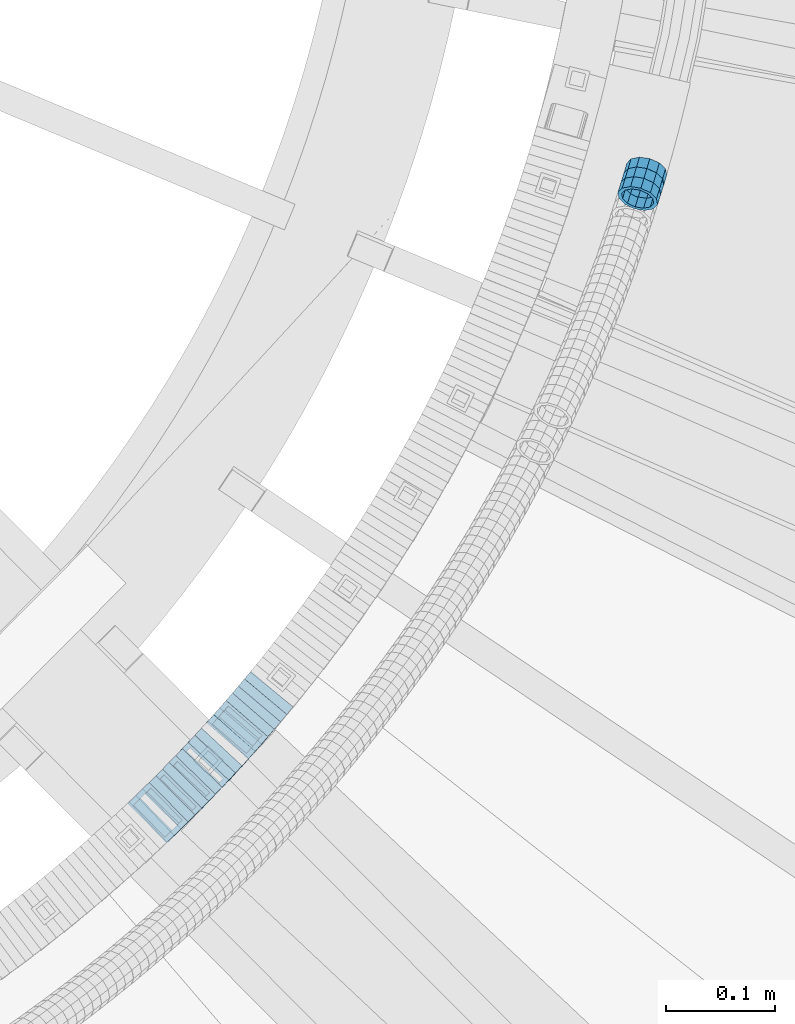
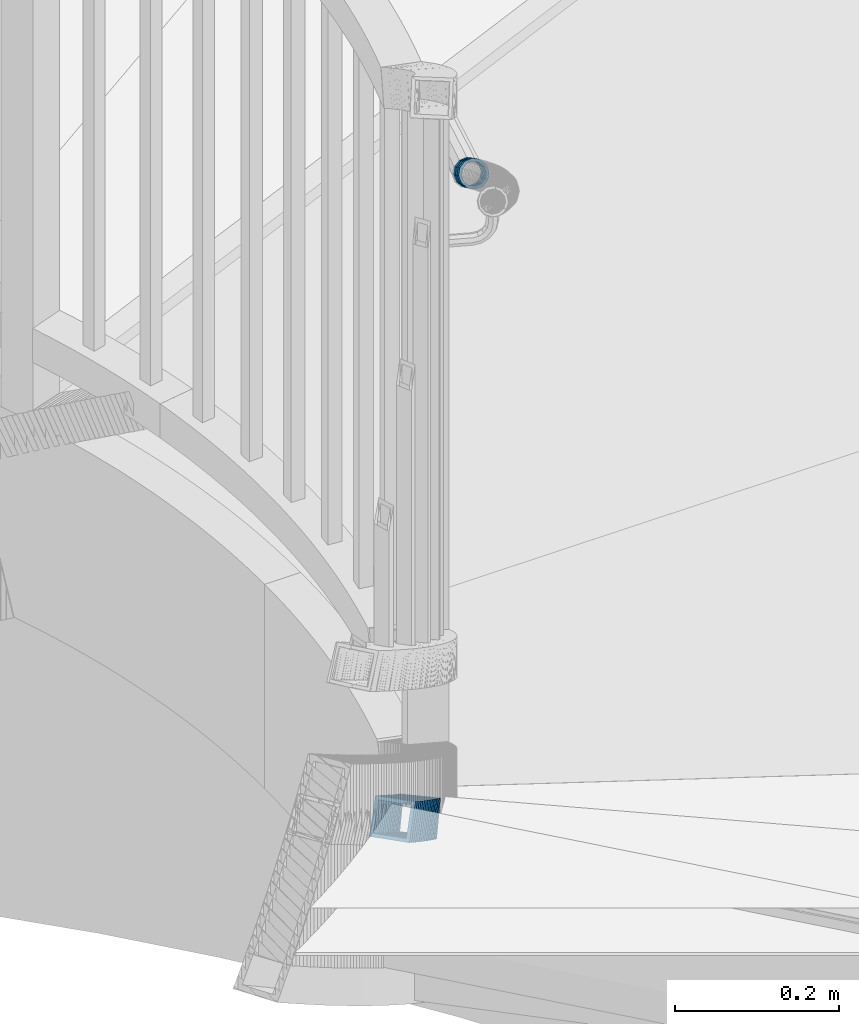
# One storey, part 791 of 975: 19 members.
"""IFC2X3 building model written with IfcOpenShell, lengths in millimetres."""

from ifc_helpers import new_model, si_unit, frame, origin_with_axes, place, context, subcontext, project, spatial, faceted_brep, material, type_object, element, save


model = new_model("IFC2X3")

# Units and contexts
model_context = context("Model", 3, precision=1e-05, world=origin_with_axes())
body_context = subcontext(model_context, "Body", "Model", "MODEL_VIEW")
ifc_project = project(units=[si_unit("LENGTHUNIT", "METRE", prefix="MILLI"), si_unit("AREAUNIT", "SQUARE_METRE"), si_unit("VOLUMEUNIT", "CUBIC_METRE"), si_unit("MASSUNIT", "GRAM", prefix="KILO"), si_unit("TIMEUNIT", "SECOND"), si_unit("PLANEANGLEUNIT", "RADIAN"), si_unit("SOLIDANGLEUNIT", "STERADIAN"), si_unit("THERMODYNAMICTEMPERATUREUNIT", "DEGREE_CELSIUS"), si_unit("LUMINOUSINTENSITYUNIT", "LUMEN")], contexts=[model_context])

# Site, building, storey
site_placement = place(None, origin_with_axes())
site = spatial("IfcSite", under=ifc_project, at=site_placement, CompositionType="ELEMENT")
building_placement = place(site_placement, origin_with_axes())
building = spatial("IfcBuilding", under=site, at=building_placement, Name="Undefined", CompositionType="ELEMENT")
storey_placement = place(building_placement, origin_with_axes())
storey = spatial("IfcBuildingStorey", under=building, at=storey_placement, Name="Undefined", CompositionType="ELEMENT", Elevation=0.0)

# Members
ifc_material = material()
member_type_1 = type_object("IfcMemberType", PredefinedType="NOTDEFINED")
member_1_placement = place(storey_placement, frame((36149.7820135626, 2972.63494042031, 3043.43100263538), z_axis=(0.955779008826956, -0.294085848496255, -2.62300090980717e-10), x_axis=(-0.251153905969039, -0.816250195900279, 0.520247376936444)))
element("IfcMember", 1, at=member_1_placement, inside=storey, type_object=member_type_1, material=ifc_material, Name="WALL", context=body_context, shape_type="Brep", body=[
    faceted_brep([(-2.1246523829177e-07, -15.367000000002, 0.0), (-1.83998054126278e-07, -13.3082123799541, 7.68350000000009), (11.154819586176, -13.3082123799522, 7.68349999999919), (11.1548195861815, -15.3669999999929, -2.91038304567337e-11), (-1.06232619145885e-07, -7.68349999999919, 13.3082123799559), (11.1548195861706, -7.68349999999737, 13.3082123799686), (-3.63797880709171e-12, 3.63797880709171e-12, 15.3670000000002), (11.1548195861687, 1.81898940354586e-12, 15.3670000000202), (1.06225343188271e-07, 7.68350000000646, 13.3082123799559), (11.1548195861687, 7.683500000001, 13.3082123799832), (1.8399441614747e-07, 13.308212379965, 7.68350000000009), (11.1548195861724, 13.3082123799559, 7.68350000001374), (2.12461600312963e-07, 15.3670000000093, 0.0), (11.1548195861778, 15.367000000002, 0.0), (1.8399441614747e-07, 13.308212379965, -7.68350000000009), (11.1548195861815, 13.3082123799613, -7.68350000002101), (1.06225343188271e-07, 7.68350000000646, -13.3082123799559), (11.1548195861869, 7.68350000000828, -13.3082123799904), (-3.63797880709171e-12, 3.63797880709171e-12, -15.3670000000002), (11.1548195861888, 9.09494701772928e-12, -15.3670000000493), (-1.06232619145885e-07, -7.68349999999919, -13.3082123799559), (11.1548195861869, -7.68349999999009, -13.308212380005), (-1.83998054126278e-07, -13.3082123799541, -7.68350000000009), (11.1548195861869, -13.3082123799468, -7.68350000003556), (-2.63386027654633e-07, -19.0500000000029, 0.0), (-2.28097633225843e-07, -16.4977839420972, -9.52499999999964), (11.1548195861869, -16.4977839420844, -9.52500000004511), (11.1548195861797, -19.0499999999938, -2.18278728425503e-11), (-1.31691194837913e-07, -9.52500000000146, -16.4977839420935), (11.1548195861906, -9.52499999998872, -16.4977839421481), (-3.63797880709171e-12, 3.63797880709171e-12, -19.0500000000002), (11.1548195861906, 9.09494701772928e-12, -19.0500000000611), (1.31687556859106e-07, 9.52500000000509, -16.4977839420935), (11.1548195861888, 9.52500000000873, -16.4977839421335), (2.28097633225843e-07, 16.4977839421044, -9.52499999999964), (11.1548195861833, 16.497783942099, -9.52500000001601), (2.63382389675826e-07, 19.0500000000138, 0.0), (11.154819586176, 19.0500000000029, 7.27595761418343e-12), (2.28097633225843e-07, 16.4977839421044, 9.52499999999964), (11.1548195861706, 16.4977839420935, 9.52500000002328), (1.31687556859106e-07, 9.52500000000509, 16.4977839420935), (11.1548195861669, 9.52499999999964, 16.497783942119), (-3.63797880709171e-12, 3.63797880709171e-12, 19.0500000000002), (11.1548195861669, -1.81898940354586e-12, 19.050000000032), (-1.31691194837913e-07, -9.52500000000146, 16.4977839420935), (11.1548195861687, -9.52499999999782, 16.4977839421117), (-2.28097633225843e-07, -16.4977839420972, 9.52499999999964), (11.154819586176, -16.4977839420881, 9.52499999999418)], [[[0, 1, 2, 3]], [[1, 4, 5, 2]], [[4, 6, 7, 5]], [[6, 8, 9, 7]], [[8, 10, 11, 9]], [[10, 12, 13, 11]], [[12, 14, 15, 13]], [[14, 16, 17, 15]], [[16, 18, 19, 17]], [[18, 20, 21, 19]], [[20, 22, 23, 21]], [[22, 0, 3, 23]], [[24, 25, 26, 27]], [[25, 28, 29, 26]], [[28, 30, 31, 29]], [[30, 32, 33, 31]], [[32, 34, 35, 33]], [[34, 36, 37, 35]], [[36, 38, 39, 37]], [[38, 40, 41, 39]], [[40, 42, 43, 41]], [[42, 44, 45, 43]], [[44, 46, 47, 45]], [[46, 24, 27, 47]], [[29, 31, 33, 35, 37, 39, 41, 43, 45, 47, 27, 26], [5, 7, 9, 11, 13, 15, 17, 19, 21, 23, 3, 2]], [[46, 44, 42, 40, 38, 36, 34, 32, 30, 28, 25, 24], [22, 20, 18, 16, 14, 12, 10, 8, 6, 4, 1, 0]]]),
])
member_2_placement = place(storey_placement, frame((36155.2620249153, 2990.6363300773, 3031.75748461078), z_axis=(0.96152394770514, -0.274721127672267, -1.43476427183486e-10), x_axis=(-0.234234233919947, -0.819819819719318, 0.522522522821093)))
element("IfcMember", 2, at=member_2_placement, inside=storey, type_object=member_type_1, material=ifc_material, Name="WALL", context=body_context, shape_type="Brep", body=[
    faceted_brep([(-2.1246523829177e-07, -15.367000000002, 0.0), (-1.83998054126278e-07, -13.3082123799541, 7.68350000000009), (11.1022520238112, -13.3082123799504, 7.68349999999919), (11.1022520238148, -15.3669999999966, -1.45519152283669e-11), (-1.06232619145885e-07, -7.68349999999919, 13.3082123799559), (11.1022520238039, -7.68349999999737, 13.3082123799759), (-3.63797880709171e-12, 3.63797880709171e-12, 15.3670000000002), (11.1022520237984, 0.0, 15.3670000000347), (1.06225343188271e-07, 7.68350000000646, 13.3082123799559), (11.102252023793, 7.68349999999737, 13.308212380005), (1.8399441614747e-07, 13.308212379965, 7.68350000000009), (11.102252023793, 13.3082123799504, 7.68350000005739), (2.12461600312963e-07, 15.3670000000093, 0.0), (11.1022520237912, 15.3669999999947, 5.82076609134674e-11), (1.8399441614747e-07, 13.308212379965, -7.68350000000009), (11.1022520237966, 13.3082123799486, -7.68349999995553), (1.06225343188271e-07, 7.68350000000646, -13.3082123799559), (11.1022520238021, 7.68349999999555, -13.3082123799322), (-3.63797880709171e-12, 3.63797880709171e-12, -15.3670000000002), (11.1022520238093, -1.81898940354586e-12, -15.3669999999984), (-1.06232619145885e-07, -7.68349999999919, -13.3082123799559), (11.102252023813, -7.68349999999919, -13.3082123799686), (-1.83998054126278e-07, -13.3082123799541, -7.68350000000009), (11.1022520238166, -13.3082123799522, -7.68350000002101), (-2.63386027654633e-07, -19.0500000000029, 0.0), (-2.28097633225843e-07, -16.4977839420972, -9.52499999999964), (11.1022520238221, -16.4977839420899, -9.52500000003056), (11.1022520238184, -19.0499999999938, -2.18278728425503e-11), (-1.31691194837913e-07, -9.52500000000146, -16.4977839420935), (11.1022520238166, -9.52499999999964, -16.4977839421117), (-3.63797880709171e-12, 3.63797880709171e-12, -19.0500000000002), (11.1022520238093, -3.63797880709171e-12, -19.0499999999956), (1.31687556859106e-07, 9.52500000000509, -16.4977839420935), (11.1022520238002, 9.52499999999418, -16.4977839420681), (2.28097633225843e-07, 16.4977839421044, -9.52499999999964), (11.1022520237948, 16.4977839420862, -9.5249999999578), (2.63382389675826e-07, 19.0500000000138, 0.0), (11.1022520237893, 19.049999999992, 5.82076609134674e-11), (2.28097633225843e-07, 16.4977839421044, 9.52499999999964), (11.1022520237893, 16.4977839420881, 9.52500000006694), (1.31687556859106e-07, 9.52500000000509, 16.4977839420935), (11.102252023793, 9.52499999999782, 16.4977839421481), (-3.63797880709171e-12, 3.63797880709171e-12, 19.0500000000002), (11.1022520237966, 0.0, 19.0500000000393), (-1.31691194837913e-07, -9.52500000000146, 16.4977839420935), (11.1022520238075, -9.524999999996, 16.4977839421117), (-2.28097633225843e-07, -16.4977839420972, 9.52499999999964), (11.1022520238148, -16.4977839420881, 9.5249999999869)], [[[0, 1, 2, 3]], [[1, 4, 5, 2]], [[4, 6, 7, 5]], [[6, 8, 9, 7]], [[8, 10, 11, 9]], [[10, 12, 13, 11]], [[12, 14, 15, 13]], [[14, 16, 17, 15]], [[16, 18, 19, 17]], [[18, 20, 21, 19]], [[20, 22, 23, 21]], [[22, 0, 3, 23]], [[24, 25, 26, 27]], [[25, 28, 29, 26]], [[28, 30, 31, 29]], [[30, 32, 33, 31]], [[32, 34, 35, 33]], [[34, 36, 37, 35]], [[36, 38, 39, 37]], [[38, 40, 41, 39]], [[40, 42, 43, 41]], [[42, 44, 45, 43]], [[44, 46, 47, 45]], [[46, 24, 27, 47]], [[29, 31, 33, 35, 37, 39, 41, 43, 45, 47, 27, 26], [5, 7, 9, 11, 13, 15, 17, 19, 21, 23, 3, 2]], [[46, 44, 42, 40, 38, 36, 34, 32, 30, 28, 25, 24], [22, 20, 18, 16, 14, 12, 10, 8, 6, 4, 1, 0]]]),
])
member_3_placement = place(storey_placement, frame((36152.4857226872, 2981.40442080969, 3037.66675568858), z_axis=(0.957826285158856, -0.287347885773997, -1.64585799211636e-10), x_axis=(-0.243351898027142, -0.81117299308944, 0.531768962058624)))
element("IfcMember", 3, at=member_3_placement, inside=storey, type_object=member_type_1, material=ifc_material, Name="WALL", context=body_context, shape_type="Brep", body=[
    faceted_brep([(-2.1246523829177e-07, -15.367000000002, 0.0), (-1.83998054126278e-07, -13.3082123799541, 7.68350000000009), (11.1022520238112, -13.3082123799504, 7.68349999999919), (11.1022520238148, -15.3669999999966, -1.45519152283669e-11), (-1.06232619145885e-07, -7.68349999999919, 13.3082123799559), (11.1022520238039, -7.68349999999737, 13.3082123799759), (-3.63797880709171e-12, 3.63797880709171e-12, 15.3670000000002), (11.1022520237984, 0.0, 15.3670000000347), (1.06225343188271e-07, 7.68350000000646, 13.3082123799559), (11.102252023793, 7.68349999999737, 13.308212380005), (1.8399441614747e-07, 13.308212379965, 7.68350000000009), (11.102252023793, 13.3082123799504, 7.68350000005739), (2.12461600312963e-07, 15.3670000000093, 0.0), (11.1022520237912, 15.3669999999947, 5.82076609134674e-11), (1.8399441614747e-07, 13.308212379965, -7.68350000000009), (11.1022520237966, 13.3082123799486, -7.68349999995553), (1.06225343188271e-07, 7.68350000000646, -13.3082123799559), (11.1022520238021, 7.68349999999555, -13.3082123799322), (-3.63797880709171e-12, 3.63797880709171e-12, -15.3670000000002), (11.1022520238093, -1.81898940354586e-12, -15.3669999999984), (-1.06232619145885e-07, -7.68349999999919, -13.3082123799559), (11.102252023813, -7.68349999999919, -13.3082123799686), (-1.83998054126278e-07, -13.3082123799541, -7.68350000000009), (11.1022520238166, -13.3082123799522, -7.68350000002101), (-2.63386027654633e-07, -19.0500000000029, 0.0), (-2.28097633225843e-07, -16.4977839420972, -9.52499999999964), (11.1022520238221, -16.4977839420899, -9.52500000003056), (11.1022520238184, -19.0499999999938, -2.18278728425503e-11), (-1.31691194837913e-07, -9.52500000000146, -16.4977839420935), (11.1022520238166, -9.52499999999964, -16.4977839421117), (-3.63797880709171e-12, 3.63797880709171e-12, -19.0500000000002), (11.1022520238093, -3.63797880709171e-12, -19.0499999999956), (1.31687556859106e-07, 9.52500000000509, -16.4977839420935), (11.1022520238002, 9.52499999999418, -16.4977839420681), (2.28097633225843e-07, 16.4977839421044, -9.52499999999964), (11.1022520237948, 16.4977839420862, -9.5249999999578), (2.63382389675826e-07, 19.0500000000138, 0.0), (11.1022520237893, 19.049999999992, 5.82076609134674e-11), (2.28097633225843e-07, 16.4977839421044, 9.52499999999964), (11.1022520237893, 16.4977839420881, 9.52500000006694), (1.31687556859106e-07, 9.52500000000509, 16.4977839420935), (11.102252023793, 9.52499999999782, 16.4977839421481), (-3.63797880709171e-12, 3.63797880709171e-12, 19.0500000000002), (11.1022520237966, 0.0, 19.0500000000393), (-1.31691194837913e-07, -9.52500000000146, 16.4977839420935), (11.1022520238075, -9.524999999996, 16.4977839421117), (-2.28097633225843e-07, -16.4977839420972, 9.52499999999964), (11.1022520238148, -16.4977839420881, 9.5249999999869)], [[[0, 1, 2, 3]], [[1, 4, 5, 2]], [[4, 6, 7, 5]], [[6, 8, 9, 7]], [[8, 10, 11, 9]], [[10, 12, 13, 11]], [[12, 14, 15, 13]], [[14, 16, 17, 15]], [[16, 18, 19, 17]], [[18, 20, 21, 19]], [[20, 22, 23, 21]], [[22, 0, 3, 23]], [[24, 25, 26, 27]], [[25, 28, 29, 26]], [[28, 30, 31, 29]], [[30, 32, 33, 31]], [[32, 34, 35, 33]], [[34, 36, 37, 35]], [[36, 38, 39, 37]], [[38, 40, 41, 39]], [[40, 42, 43, 41]], [[42, 44, 45, 43]], [[44, 46, 47, 45]], [[46, 24, 27, 47]], [[29, 31, 33, 35, 37, 39, 41, 43, 45, 47, 27, 26], [5, 7, 9, 11, 13, 15, 17, 19, 21, 23, 3, 2]], [[46, 44, 42, 40, 38, 36, 34, 32, 30, 28, 25, 24], [22, 20, 18, 16, 14, 12, 10, 8, 6, 4, 1, 0]]]),
])
member_type_2 = type_object("IfcMemberType", Name="HSS2X2X.188_TUBES", PredefinedType="NOTDEFINED")
member_4_placement = place(storey_placement, frame((35713.0261514051, 2406.30820781357, 2576.76307719514), z_axis=(0.701517264451547, -0.712652459250944, 3.59814748662756e-10), x_axis=(-0.598653957047596, -0.589299989046794, 0.542530149043077)))
element("IfcMember", 4, at=member_4_placement, inside=storey, type_object=member_type_2, material=ifc_material, Name="WALL", ObjectType="HSS2X2X.188_TUBES", context=body_context, shape_type="Brep", body=[
    faceted_brep([(0.0, 20.6374999999753, -20.6375000000298), (0.0, -20.6375000000153, -20.6375000000153), (10.6906501205649, -20.6374999999844, -20.637499999968), (10.690650120574, 20.6375000000098, -20.6374999999716), (0.0, -20.6374999999825, 20.6375000000335), (10.6906501205467, -20.6374999999844, 20.637500000008), (0.0, 20.6375000000116, 20.6375000000189), (10.6906501205558, 20.637500000008, 20.6375000000007), (0.0, 25.3999999999724, -25.4000000000342), (0.0, 25.400000000016, 25.4000000000196), (10.6906501205522, 25.4000000000087, 25.3999999999978), (10.6906501205813, 25.4000000000124, -25.3999999999651), (0.0, -25.399999999976, 25.4000000000378), (10.6906501205431, -25.3999999999833, 25.4000000000051), (0.0, -25.400000000016, -25.4000000000196), (10.6906501205704, -25.3999999999833, -25.3999999999614)], [[[0, 1, 2, 3]], [[1, 4, 5, 2]], [[4, 6, 7, 5]], [[6, 0, 3, 7]], [[8, 9, 10, 11]], [[9, 12, 13, 10]], [[12, 14, 15, 13]], [[14, 8, 11, 15]], [[13, 15, 11, 10], [5, 7, 3, 2]], [[14, 12, 9, 8], [6, 4, 1, 0]]]),
])
member_5_placement = place(storey_placement, frame((35719.1061186458, 2412.17895941383, 2571.05354306446), z_axis=(0.712740827757807, -0.701427481958838, 9.06311470316723e-11), x_axis=(-0.589487856176559, -0.598995724179502, 0.5419485121624)))
element("IfcMember", 5, at=member_5_placement, inside=storey, type_object=member_type_2, material=ifc_material, Name="WALL", ObjectType="HSS2X2X.188_TUBES", context=body_context, shape_type="Brep", body=[
    faceted_brep([(0.0, 20.6374999999753, -20.6375000000298), (0.0, -20.6375000000153, -20.6375000000153), (10.5190303735253, -20.6375000000171, -20.6375000000444), (10.5190303734962, 20.6374999999607, -20.6375000000808), (0.0, -20.6374999999825, 20.6375000000335), (10.5190303735744, -20.6374999999844, 20.6375000000407), (0.0, 20.6375000000116, 20.6375000000189), (10.5190303735435, 20.6374999999916, 20.6375000000044), (0.0, 25.3999999999724, -25.4000000000342), (0.0, 25.400000000016, 25.4000000000196), (10.5190303735435, 25.3999999999942, 25.4000000000124), (10.5190303734835, 25.3999999999523, -25.4000000000924), (0.0, -25.399999999976, 25.4000000000378), (10.5190303735853, -25.399999999976, 25.400000000056), (0.0, -25.400000000016, -25.4000000000196), (10.5190303735235, -25.4000000000196, -25.4000000000451)], [[[0, 1, 2, 3]], [[1, 4, 5, 2]], [[4, 6, 7, 5]], [[6, 0, 3, 7]], [[8, 9, 10, 11]], [[9, 12, 13, 10]], [[12, 14, 15, 13]], [[14, 8, 11, 15]], [[13, 15, 11, 10], [5, 7, 3, 2]], [[14, 12, 9, 8], [6, 4, 1, 0]]]),
])
member_6_placement = place(storey_placement, frame((35725.5152764884, 2418.69232217269, 2565.25491286781), z_axis=(0.712652459251016, -0.701517264451473, -3.59879322786582e-10), x_axis=(-0.592287356936455, -0.601688743935535, 0.535879036942579)))
element("IfcMember", 6, at=member_6_placement, inside=storey, type_object=member_type_2, material=ifc_material, Name="WALL", ObjectType="HSS2X2X.188_TUBES", context=body_context, shape_type="Brep", body=[
    faceted_brep([(0.0, 20.6374999999753, -20.6375000000298), (0.0, -20.6375000000153, -20.6375000000153), (10.6395488625676, -20.6374999999771, -20.6374999999716), (10.6395488625531, 20.6374999999916, -20.6375000000189), (0.0, -20.6374999999825, 20.6375000000335), (10.6395488625731, -20.6374999999844, 20.6375000000153), (0.0, 20.6375000000116, 20.6375000000189), (10.6395488625585, 20.6374999999825, 20.637499999968), (0.0, 25.3999999999724, -25.4000000000342), (0.0, 25.400000000016, 25.4000000000196), (10.6395488625567, 25.3999999999778, 25.3999999999614), (10.6395488625494, 25.3999999999887, -25.4000000000233), (0.0, -25.399999999976, 25.4000000000378), (10.6395488625749, -25.3999999999851, 25.400000000016), (0.0, -25.400000000016, -25.4000000000196), (10.6395488625658, -25.399999999976, -25.3999999999687)], [[[0, 1, 2, 3]], [[1, 4, 5, 2]], [[4, 6, 7, 5]], [[6, 0, 3, 7]], [[8, 9, 10, 11]], [[9, 12, 13, 10]], [[12, 14, 15, 13]], [[14, 8, 11, 15]], [[13, 15, 11, 10], [5, 7, 3, 2]], [[14, 12, 9, 8], [6, 4, 1, 0]]]),
])
member_7_placement = place(storey_placement, frame((35731.5984770764, 2424.81646858918, 2559.60322446153), z_axis=(0.718240222846302, -0.69579521576804, -3.81628524337429e-11), x_axis=(-0.586132836860171, -0.605040347855586, 0.538864059871356)))
element("IfcMember", 7, at=member_7_placement, inside=storey, type_object=member_type_2, material=ifc_material, Name="WALL", ObjectType="HSS2X2X.188_TUBES", context=body_context, shape_type="Brep", body=[
    faceted_brep([(0.0, 20.6374999999753, -20.6375000000298), (0.0, -20.6375000000153, -20.6375000000153), (10.5806427026419, -20.6374999999607, -20.6374999999316), (10.5806427026473, 20.6375000000444, -20.6374999999207), (0.0, -20.6374999999825, 20.6375000000335), (10.5806427025509, -20.6375000000207, 20.6374999999643), (0.0, 20.6375000000116, 20.6375000000189), (10.5806427025545, 20.6374999999862, 20.6374999999716), (0.0, 25.3999999999724, -25.4000000000342), (0.0, 25.400000000016, 25.4000000000196), (10.5806427025436, 25.3999999999796, 25.3999999999614), (10.5806427026582, 25.4000000000542, -25.3999999999105), (0.0, -25.399999999976, 25.4000000000378), (10.5806427025418, -25.4000000000287, 25.3999999999542), (0.0, -25.400000000016, -25.4000000000196), (10.5806427026528, -25.3999999999542, -25.3999999999178)], [[[0, 1, 2, 3]], [[1, 4, 5, 2]], [[4, 6, 7, 5]], [[6, 0, 3, 7]], [[8, 9, 10, 11]], [[9, 12, 13, 10]], [[12, 14, 15, 13]], [[14, 8, 11, 15]], [[13, 15, 11, 10], [5, 7, 3, 2]], [[14, 12, 9, 8], [6, 4, 1, 0]]]),
])
member_8_placement = place(storey_placement, frame((35737.6808177588, 2431.09501380966, 2553.91234156435), z_axis=(0.718240222846302, -0.69579521576804, -3.81628524337429e-11), x_axis=(-0.583143735824596, -0.601954824818908, 0.54552155983588)))
element("IfcMember", 8, at=member_8_placement, inside=storey, type_object=member_type_2, material=ifc_material, Name="WALL", ObjectType="HSS2X2X.188_TUBES", context=body_context, shape_type="Brep", body=[
    faceted_brep([(0.0, 20.6374999999753, -20.6375000000298), (0.0, -20.6375000000153, -20.6375000000153), (10.6348483769107, -20.637499999988, -20.6374999999825), (10.6348483768415, 20.6374999999734, -20.6375000001026), (0.0, -20.6374999999825, 20.6375000000335), (10.6348483769852, -20.6374999999589, 20.6375000001462), (0.0, 20.6375000000116, 20.6375000000189), (10.6348483769161, 20.6375000000044, 20.6375000000226), (0.0, 25.3999999999724, -25.4000000000342), (0.0, 25.400000000016, 25.4000000000196), (10.6348483769179, 25.4000000000015, 25.4000000000233), (10.6348483768288, 25.3999999999669, -25.4000000001324), (0.0, -25.399999999976, 25.4000000000378), (10.6348483769998, -25.3999999999505, 25.4000000001688), (0.0, -25.400000000016, -25.4000000000196), (10.6348483769107, -25.3999999999887, -25.3999999999833)], [[[0, 1, 2, 3]], [[1, 4, 5, 2]], [[4, 6, 7, 5]], [[6, 0, 3, 7]], [[8, 9, 10, 11]], [[9, 12, 13, 10]], [[12, 14, 15, 13]], [[14, 8, 11, 15]], [[13, 15, 11, 10], [5, 7, 3, 2]], [[14, 12, 9, 8], [6, 4, 1, 0]]]),
])
member_9_placement = place(storey_placement, frame((35743.7800747455, 2437.27769199091, 2548.10087833793), z_axis=(0.729187266868911, -0.684314204029295, 7.10215317667462e-11), x_axis=(-0.576524524206887, -0.614329411220378, 0.538719637193267)))
element("IfcMember", 9, at=member_9_placement, inside=storey, type_object=member_type_2, material=ifc_material, Name="WALL", ObjectType="HSS2X2X.188_TUBES", context=body_context, shape_type="Brep", body=[
    faceted_brep([(0.0, 20.6374999999753, -20.6375000000298), (0.0, -20.6375000000153, -20.6375000000153), (10.5806427026419, -20.6374999999607, -20.6374999999316), (10.5806427026473, 20.6375000000444, -20.6374999999207), (0.0, -20.6374999999825, 20.6375000000335), (10.5806427025509, -20.6375000000207, 20.6374999999643), (0.0, 20.6375000000116, 20.6375000000189), (10.5806427025545, 20.6374999999862, 20.6374999999716), (0.0, 25.3999999999724, -25.4000000000342), (0.0, 25.400000000016, 25.4000000000196), (10.5806427025436, 25.3999999999796, 25.3999999999614), (10.5806427026582, 25.4000000000542, -25.3999999999105), (0.0, -25.399999999976, 25.4000000000378), (10.5806427025418, -25.4000000000287, 25.3999999999542), (0.0, -25.400000000016, -25.4000000000196), (10.5806427026528, -25.3999999999542, -25.3999999999178)], [[[0, 1, 2, 3]], [[1, 4, 5, 2]], [[4, 6, 7, 5]], [[6, 0, 3, 7]], [[8, 9, 10, 11]], [[9, 12, 13, 10]], [[12, 14, 15, 13]], [[14, 8, 11, 15]], [[13, 15, 11, 10], [5, 7, 3, 2]], [[14, 12, 9, 8], [6, 4, 1, 0]]]),
])
member_10_placement = place(storey_placement, frame((35749.8783761441, 2443.72343410136, 2542.35033670451), z_axis=(0.734376708367199, -0.678742108762789, -2.68556050286861e-10), x_axis=(-0.573180696785189, -0.620162721767527, 0.535595077799207)))
element("IfcMember", 10, at=member_10_placement, inside=storey, type_object=member_type_2, material=ifc_material, Name="WALL", ObjectType="HSS2X2X.188_TUBES", context=body_context, shape_type="Brep", body=[
    faceted_brep([(0.0, 20.6374999999753, -20.6375000000298), (0.0, -20.6375000000153, -20.6375000000153), (10.6395488625676, -20.6374999999771, -20.6374999999716), (10.6395488625531, 20.6374999999916, -20.6375000000189), (0.0, -20.6374999999825, 20.6375000000335), (10.6395488625731, -20.6374999999844, 20.6375000000153), (0.0, 20.6375000000116, 20.6375000000189), (10.6395488625585, 20.6374999999825, 20.637499999968), (0.0, 25.3999999999724, -25.4000000000342), (0.0, 25.400000000016, 25.4000000000196), (10.6395488625567, 25.3999999999778, 25.3999999999614), (10.6395488625494, 25.3999999999887, -25.4000000000233), (0.0, -25.399999999976, 25.4000000000378), (10.6395488625749, -25.3999999999851, 25.400000000016), (0.0, -25.400000000016, -25.4000000000196), (10.6395488625658, -25.399999999976, -25.3999999999687)], [[[0, 1, 2, 3]], [[1, 4, 5, 2]], [[4, 6, 7, 5]], [[6, 0, 3, 7]], [[8, 9, 10, 11]], [[9, 12, 13, 10]], [[12, 14, 15, 13]], [[14, 8, 11, 15]], [[13, 15, 11, 10], [5, 7, 3, 2]], [[14, 12, 9, 8], [6, 4, 1, 0]]]),
])
member_11_placement = place(storey_placement, frame((35755.8643620431, 2450.25439157036, 2536.70994936357), z_axis=(0.729187266868911, -0.684314204029295, 7.10215317667462e-11), x_axis=(-0.573585986715, -0.611198182696374, 0.545376839729035)))
element("IfcMember", 11, at=member_11_placement, inside=storey, type_object=member_type_2, material=ifc_material, Name="WALL", ObjectType="HSS2X2X.188_TUBES", context=body_context, shape_type="Brep", body=[
    faceted_brep([(0.0, 20.6374999999753, -20.6375000000298), (0.0, -20.6375000000153, -20.6375000000153), (10.6348483769107, -20.637499999988, -20.6374999999825), (10.6348483768415, 20.6374999999734, -20.6375000001026), (0.0, -20.6374999999825, 20.6375000000335), (10.6348483769852, -20.6374999999589, 20.6375000001462), (0.0, 20.6375000000116, 20.6375000000189), (10.6348483769161, 20.6375000000044, 20.6375000000226), (0.0, 25.3999999999724, -25.4000000000342), (0.0, 25.400000000016, 25.4000000000196), (10.6348483769179, 25.4000000000015, 25.4000000000233), (10.6348483768288, 25.3999999999669, -25.4000000001324), (0.0, -25.399999999976, 25.4000000000378), (10.6348483769998, -25.3999999999505, 25.4000000001688), (0.0, -25.400000000016, -25.4000000000196), (10.6348483769107, -25.3999999999887, -25.3999999999833)], [[[0, 1, 2, 3]], [[1, 4, 5, 2]], [[4, 6, 7, 5]], [[6, 0, 3, 7]], [[8, 9, 10, 11]], [[9, 12, 13, 10]], [[12, 14, 15, 13]], [[14, 8, 11, 15]], [[13, 15, 11, 10], [5, 7, 3, 2]], [[14, 12, 9, 8], [6, 4, 1, 0]]]),
])
for number, where, z_axis, x_axis, name in (
    (12, (35761.8703566823, 2456.53938343108, 2530.89697428563), (0.739940073305354, -0.672672794095961, -8.58849489304701e-11), (-0.566820201285187, -0.623502221313754, 0.538479191270967), "WALL"),
    (13, (35767.6692874342, 2462.80194984014, 2525.19152149674), (0.750491265210869, -0.660880368026006, -7.65185177442618e-11), (-0.55702532101342, -0.632554178015136, 0.538143107012895), "WALL"),
):
    element("IfcMember", number, at=place(storey_placement, frame(where, z_axis=z_axis, x_axis=x_axis)), inside=storey, type_object=member_type_2, material=ifc_material, Name=name, ObjectType="HSS2X2X.188_TUBES", context=body_context, shape_type="Brep", body=[
        faceted_brep([(0.0, 20.6374999999753, -20.6375000000298), (0.0, -20.6375000000153, -20.6375000000153), (10.5948100501191, -20.6375000000335, -20.6375000000844), (10.5948100501555, 20.6374999999971, -20.6375000000116), (0.0, -20.6374999999825, 20.6375000000335), (10.5948100501446, -20.6375000000098, 20.6374999999571), (0.0, 20.6375000000116, 20.6375000000189), (10.5948100501828, 20.6375000000189, 20.6375000000298), (0.0, 25.3999999999724, -25.4000000000342), (0.0, 25.400000000016, 25.4000000000196), (10.5948100501919, 25.4000000000251, 25.4000000000451), (10.5948100501591, 25.3999999999978, -25.4000000000051), (0.0, -25.399999999976, 25.4000000000378), (10.5948100501482, -25.4000000000106, 25.3999999999578), (0.0, -25.400000000016, -25.4000000000196), (10.5948100501118, -25.4000000000378, -25.400000000096)], [[[0, 1, 2, 3]], [[1, 4, 5, 2]], [[4, 6, 7, 5]], [[6, 0, 3, 7]], [[8, 9, 10, 11]], [[9, 12, 13, 10]], [[12, 14, 15, 13]], [[14, 8, 11, 15]], [[13, 15, 11, 10], [5, 7, 3, 2]], [[14, 12, 9, 8], [6, 4, 1, 0]]]),
    ])
member_12_placement = place(storey_placement, frame((35773.7727183759, 2469.78974565235, 2519.44577120091), z_axis=(0.744950446796735, -0.667119803196805, 1.78856680577155e-10), x_axis=(-0.563485862174004, -0.62922587919428, 0.53531156916529)))
element("IfcMember", 14, at=member_12_placement, inside=storey, type_object=member_type_2, material=ifc_material, Name="WALL", ObjectType="HSS2X2X.188_TUBES", context=body_context, shape_type="Brep", body=[
    faceted_brep([(0.0, 20.6374999999753, -20.6375000000298), (0.0, -20.6375000000153, -20.6375000000153), (10.648004507897, -20.6374999999862, -20.637499999968), (10.6480045078188, 20.6374999999771, -20.6375000000808), (0.0, -20.6374999999825, 20.6375000000335), (10.6480045079406, -20.6374999999698, 20.6375000001062), (0.0, 20.6375000000116, 20.6375000000189), (10.6480045078679, 20.6374999999935, 20.6375000000007), (0.0, 25.3999999999724, -25.4000000000342), (0.0, 25.400000000016, 25.4000000000196), (10.6480045078661, 25.3999999999905, 25.4000000000015), (10.648004507806, 25.3999999999705, -25.4000000000997), (0.0, -25.399999999976, 25.4000000000378), (10.6480045079552, -25.3999999999633, 25.4000000001288), (0.0, -25.400000000016, -25.4000000000196), (10.6480045078988, -25.3999999999814, -25.3999999999651)], [[[0, 1, 2, 3]], [[1, 4, 5, 2]], [[4, 6, 7, 5]], [[6, 0, 3, 7]], [[8, 9, 10, 11]], [[9, 12, 13, 10]], [[12, 14, 15, 13]], [[14, 8, 11, 15]], [[13, 15, 11, 10], [5, 7, 3, 2]], [[14, 12, 9, 8], [6, 4, 1, 0]]]),
])
member_13_placement = place(storey_placement, frame((35779.2572462389, 2475.78152948542, 2513.8473468106), z_axis=(0.756061291784399, -0.654500819759078, -2.68632902589162e-11), x_axis=(-0.547633029096188, -0.632610568111114, 0.547633029096188)))
element("IfcMember", 15, at=member_13_placement, inside=storey, type_object=member_type_2, material=ifc_material, Name="WALL", ObjectType="HSS2X2X.188_TUBES", context=body_context, shape_type="Brep", body=[
    faceted_brep([(0.0, 20.6374999999753, -20.6375000000298), (0.0, -20.6375000000153, -20.6375000000153), (10.5948100501191, -20.6375000000335, -20.6375000000844), (10.5948100501555, 20.6374999999971, -20.6375000000116), (0.0, -20.6374999999825, 20.6375000000335), (10.5948100501446, -20.6375000000098, 20.6374999999571), (0.0, 20.6375000000116, 20.6375000000189), (10.5948100501828, 20.6375000000189, 20.6375000000298), (0.0, 25.3999999999724, -25.4000000000342), (0.0, 25.400000000016, 25.4000000000196), (10.5948100501919, 25.4000000000251, 25.4000000000451), (10.5948100501591, 25.3999999999978, -25.4000000000051), (0.0, -25.399999999976, 25.4000000000378), (10.5948100501482, -25.4000000000106, 25.3999999999578), (0.0, -25.400000000016, -25.4000000000196), (10.5948100501118, -25.4000000000378, -25.400000000096)], [[[0, 1, 2, 3]], [[1, 4, 5, 2]], [[4, 6, 7, 5]], [[6, 0, 3, 7]], [[8, 9, 10, 11]], [[9, 12, 13, 10]], [[12, 14, 15, 13]], [[14, 8, 11, 15]], [[13, 15, 11, 10], [5, 7, 3, 2]], [[14, 12, 9, 8], [6, 4, 1, 0]]]),
])
member_14_placement = place(storey_placement, frame((35785.3755376804, 2482.85708824703, 2507.93970037974), z_axis=(0.755322467394303, -0.655353317111756, -1.10163909994298e-10), x_axis=(-0.553703879785737, -0.638167183753146, 0.534934256793114)))
element("IfcMember", 16, at=member_14_placement, inside=storey, type_object=member_type_2, material=ifc_material, Name="WALL", ObjectType="HSS2X2X.188_TUBES", context=body_context, shape_type="Brep", body=[
    faceted_brep([(0.0, 20.6374999999753, -20.6375000000298), (0.0, -20.6375000000153, -20.6375000000153), (10.6625512894789, -20.6374999999625, -20.6374999999389), (10.6625512893879, 20.6374999999789, -20.6375000000371), (0.0, -20.6374999999825, 20.6375000000335), (10.6625512894352, -20.6374999999989, 20.6375000000153), (0.0, 20.6375000000116, 20.6375000000189), (10.6625512893443, 20.6374999999443, 20.6374999999134), (0.0, 25.3999999999724, -25.4000000000342), (0.0, 25.400000000016, 25.4000000000196), (10.6625512893297, 25.3999999999342, 25.3999999998996), (10.6625512893916, 25.399999999976, -25.4000000000415), (0.0, -25.399999999976, 25.4000000000378), (10.6625512894389, -25.399999999996, 25.400000000016), (0.0, -25.400000000016, -25.4000000000196), (10.6625512894971, -25.3999999999523, -25.3999999999214)], [[[0, 1, 2, 3]], [[1, 4, 5, 2]], [[4, 6, 7, 5]], [[6, 0, 3, 7]], [[8, 9, 10, 11]], [[9, 12, 13, 10]], [[12, 14, 15, 13]], [[14, 8, 11, 15]], [[13, 15, 11, 10], [5, 7, 3, 2]], [[14, 12, 9, 8], [6, 4, 1, 0]]]),
])
for number, where, z_axis, x_axis, name in (
    (17, (35791.0768111456, 2489.36579254663, 2502.28453276387), (0.760833952037136, -0.648946605991242, -1.96182554645929e-11), (-0.547145463784104, -0.641480888746982, 0.537711921787922), "WALL"),
    (18, (35796.5716850057, 2495.74022933671, 2496.63924652357), (0.766370513915105, -0.642398813356235, 2.14107785723172e-10), (-0.537711921787912, -0.641480888746931, 0.547145463784173), "WALL"),
):
    element("IfcMember", number, at=place(storey_placement, frame(where, z_axis=z_axis, x_axis=x_axis)), inside=storey, type_object=member_type_2, material=ifc_material, Name=name, ObjectType="HSS2X2X.188_TUBES", context=body_context, shape_type="Brep", body=[
        faceted_brep([(0.0, 20.6374999999753, -20.6375000000298), (0.0, -20.6375000000153, -20.6375000000153), (10.6004716875832, -20.6375000000153, -20.6375000000553), (10.6004716875814, 20.6374999999898, -20.6375000000444), (0.0, -20.6374999999825, 20.6375000000335), (10.6004716876068, -20.6375000000044, 20.6374999999862), (0.0, 20.6375000000116, 20.6375000000189), (10.6004716876032, 20.6374999999989, 20.6374999999971), (0.0, 25.3999999999724, -25.4000000000342), (0.0, 25.400000000016, 25.4000000000196), (10.600471687605, 25.4000000000015, 25.4000000000051), (10.6004716875814, 25.3999999999869, -25.4000000000487), (0.0, -25.399999999976, 25.4000000000378), (10.6004716876068, -25.4000000000015, 25.3999999999905), (0.0, -25.400000000016, -25.4000000000196), (10.6004716875814, -25.4000000000178, -25.4000000000669)], [[[0, 1, 2, 3]], [[1, 4, 5, 2]], [[4, 6, 7, 5]], [[6, 0, 3, 7]], [[8, 9, 10, 11]], [[9, 12, 13, 10]], [[12, 14, 15, 13]], [[14, 8, 11, 15]], [[13, 15, 11, 10], [5, 7, 3, 2]], [[14, 12, 9, 8], [6, 4, 1, 0]]]),
    ])
member_15_placement = place(storey_placement, frame((35802.5867711388, 2502.92585010653, 2490.73213827413), z_axis=(0.765486270925153, -0.643452227461452, -2.30234036280308e-10), x_axis=(-0.543840293092631, -0.646982418110147, 0.534463737090991)))
element("IfcMember", 19, at=member_15_placement, inside=storey, type_object=member_type_2, material=ifc_material, Name="WALL", ObjectType="HSS2X2X.188_TUBES", context=body_context, shape_type="Brep", body=[
    faceted_brep([(0.0, 20.6374999999753, -20.6375000000298), (0.0, -20.6375000000153, -20.6375000000153), (10.6625512894789, -20.6374999999625, -20.6374999999389), (10.6625512893879, 20.6374999999789, -20.6375000000371), (0.0, -20.6374999999825, 20.6375000000335), (10.6625512894352, -20.6374999999989, 20.6375000000153), (0.0, 20.6375000000116, 20.6375000000189), (10.6625512893443, 20.6374999999443, 20.6374999999134), (0.0, 25.3999999999724, -25.4000000000342), (0.0, 25.400000000016, 25.4000000000196), (10.6625512893297, 25.3999999999342, 25.3999999998996), (10.6625512893916, 25.399999999976, -25.4000000000415), (0.0, -25.399999999976, 25.4000000000378), (10.6625512894389, -25.399999999996, 25.400000000016), (0.0, -25.400000000016, -25.4000000000196), (10.6625512894971, -25.3999999999523, -25.3999999999214)], [[[0, 1, 2, 3]], [[1, 4, 5, 2]], [[4, 6, 7, 5]], [[6, 0, 3, 7]], [[8, 9, 10, 11]], [[9, 12, 13, 10]], [[12, 14, 15, 13]], [[14, 8, 11, 15]], [[13, 15, 11, 10], [5, 7, 3, 2]], [[14, 12, 9, 8], [6, 4, 1, 0]]]),
])

save(model, "model.ifc")
